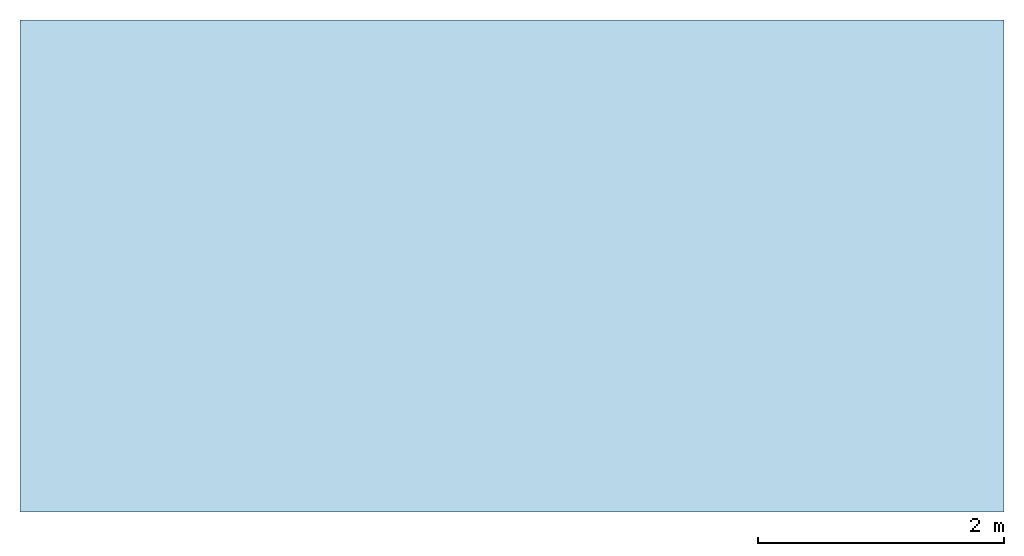
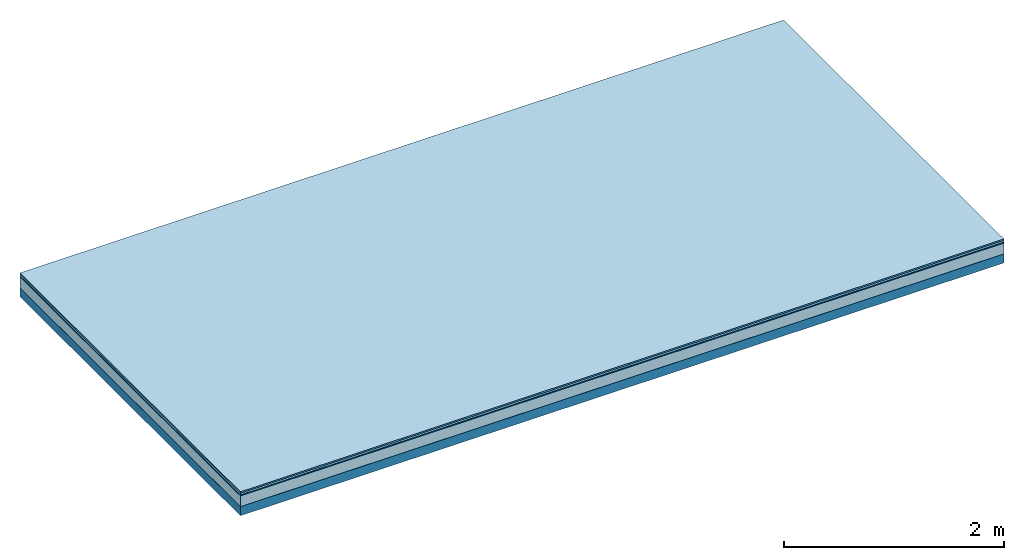
# One storey: 5 plates, 1 member, 1 element without a shape of its own.
"""IFC4 building model written with IfcOpenShell, lengths in metres."""

from ifc_helpers import new_model, si_unit, derived_unit, direction, frame, frame_2d, origin, origin_with_axes, place, context, project, spatial, rectangle, extrude, material, layer, layer_set, type_object, element, aggregate, save


model = new_model("IFC4")

# Units and contexts
plan_context = context("Plan", 3, precision=1e-05, world=origin(), true_north=direction((0.0, 1.0)))
model_context = context("Model", 3, precision=1e-05, world=origin(), true_north=direction((0.0, 1.0)))
ifc_project = project(units=[si_unit("LENGTHUNIT", "METRE"), derived_unit("SOUNDPRESSUREUNIT", [(si_unit("PRESSUREUNIT", "PASCAL", prefix="MICRO"), 0)]), si_unit("ENERGYUNIT", "JOULE", prefix="MEGA"), si_unit("MASSUNIT", "GRAM", prefix="KILO"), derived_unit("THERMALTRANSMITTANCEUNIT", [(si_unit("POWERUNIT", "WATT"), 1), (si_unit("AREAUNIT", "SQUARE_METRE"), -1), (si_unit("THERMODYNAMICTEMPERATUREUNIT", "KELVIN"), -1)]), derived_unit("AREADENSITYUNIT", [(si_unit("MASSUNIT", "GRAM", prefix="KILO"), 1), (si_unit("AREAUNIT", "SQUARE_METRE"), -1)]), derived_unit("USERDEFINED", [(si_unit("ENERGYUNIT", "JOULE", prefix="MEGA"), 1), (si_unit("AREAUNIT", "SQUARE_METRE"), -1)])], contexts=[plan_context, model_context])

# Site, building, storey
site = spatial("IfcSite", under=ifc_project)
building_placement = place(None, origin())
building = spatial("IfcBuilding", under=site, at=building_placement)
storey_placement = place(building_placement, origin())
storey = spatial("IfcBuildingStorey", under=building, at=storey_placement)

# Slab, member, plates
ifc_material_1 = material(Category="11.013")
ifc_layer_1 = layer(ifc_material_1, 0.015, Name="Flooring")
ifc_material_2 = material(Category="03.007")
ifc_layer_2 = layer(ifc_material_2, 0.02, Name="On-material")
ifc_material_3 = material(Name="Wood fiber generic product", Category="10.009")
ifc_layer_3 = layer(ifc_material_3, 0.01, Name="Impact sound insulation")
ifc_material_4 = material(Category="03.011")
ifc_layer_4 = layer(ifc_material_4, 0.12, Name="on Supporting structure")
ifc_material_5 = material(Name="protection", Category="09.007")
ifc_layer_5 = layer(ifc_material_5, 0.0005, Name="Sub-floor")
ifc_material_6 = material(Name="no composite action")
ifc_layer_6 = layer(ifc_material_6, 0.0, Name="Bond")
ifc_layer_7 = layer(None, 0.1, Name="Supporting structure")
ifc_layer_set = layer_set([ifc_layer_1, ifc_layer_2, ifc_layer_3, ifc_layer_4, ifc_layer_5, ifc_layer_6, ifc_layer_7])
slab_type = type_object("IfcSlabType", Name="A2050", PredefinedType="NOTDEFINED", material=ifc_layer_set)
slab_placement = place(None, frame((0.0, 0.0, 0.0), z_axis=(0.0, 0.0, -1.0), x_axis=(1.0, 0.0, 0.0)))
slab = element("IfcSlab", 1, at=slab_placement, inside=storey, type_object=slab_type, material=ifc_layer_set, Name="Slab #1")
ifc_material_7 = material(Name="Solid timber panel")
member_placement = place(slab_placement, origin())
member = element("IfcMember", 2, at=member_placement, material=ifc_material_7, Name="Supporting structure", context=plan_context, shape_type="SweptSolid", body=[
    extrude(rectangle(XDim=1.0, YDim=0.1, at=frame_2d((0.5, 0.05), x_axis=(1.0, 0.0))), frame((0.0, 4.0, 0.1655), z_axis=(0.0, -1.0, 0.0), x_axis=(1.0, 0.0, 0.0)), (0.0, 0.0, 1.0), 4.0),
    extrude(rectangle(XDim=1.0, YDim=0.1, at=frame_2d((0.5, 0.05), x_axis=(1.0, 0.0))), frame((1.0, 4.0, 0.1655), z_axis=(0.0, -1.0, 0.0), x_axis=(1.0, 0.0, 0.0)), (0.0, 0.0, 1.0), 4.0),
    extrude(rectangle(XDim=1.0, YDim=0.1, at=frame_2d((0.5, 0.05), x_axis=(1.0, 0.0))), frame((2.0, 4.0, 0.1655), z_axis=(0.0, -1.0, 0.0), x_axis=(1.0, 0.0, 0.0)), (0.0, 0.0, 1.0), 4.0),
    extrude(rectangle(XDim=1.0, YDim=0.1, at=frame_2d((0.5, 0.05), x_axis=(1.0, 0.0))), frame((3.0, 4.0, 0.1655), z_axis=(0.0, -1.0, 0.0), x_axis=(1.0, 0.0, 0.0)), (0.0, 0.0, 1.0), 4.0),
    extrude(rectangle(XDim=1.0, YDim=0.1, at=frame_2d((0.5, 0.05), x_axis=(1.0, 0.0))), frame((4.0, 4.0, 0.1655), z_axis=(0.0, -1.0, 0.0), x_axis=(1.0, 0.0, 0.0)), (0.0, 0.0, 1.0), 4.0),
    extrude(rectangle(XDim=1.0, YDim=0.1, at=frame_2d((0.5, 0.05), x_axis=(1.0, 0.0))), frame((5.0, 4.0, 0.1655), z_axis=(0.0, -1.0, 0.0), x_axis=(1.0, 0.0, 0.0)), (0.0, 0.0, 1.0), 4.0),
    extrude(rectangle(XDim=1.0, YDim=0.1, at=frame_2d((0.5, 0.05), x_axis=(1.0, 0.0))), frame((6.0, 4.0, 0.1655), z_axis=(0.0, -1.0, 0.0), x_axis=(1.0, 0.0, 0.0)), (0.0, 0.0, 1.0), 4.0),
    extrude(rectangle(XDim=1.0, YDim=0.1, at=frame_2d((0.5, 0.05), x_axis=(1.0, 0.0))), frame((7.0, 4.0, 0.1655), z_axis=(0.0, -1.0, 0.0), x_axis=(1.0, 0.0, 0.0)), (0.0, 0.0, 1.0), 4.0),
])
plate_1_placement = place(slab_placement, origin())
plate_1 = element("IfcPlate", 3, at=plate_1_placement, material=ifc_material_1, Name="Flooring", context=plan_context, shape_type="SweptSolid", body=[
    extrude(rectangle(XDim=8.0, YDim=4.0, at=frame_2d((4.0, 2.0), x_axis=(1.0, 0.0))), origin_with_axes(), (0.0, 0.0, 1.0), 0.015),
])
plate_2_placement = place(slab_placement, origin())
plate_2 = element("IfcPlate", 4, at=plate_2_placement, material=ifc_material_2, Name="On-material", context=plan_context, shape_type="SweptSolid", body=[
    extrude(rectangle(XDim=8.0, YDim=4.0, at=frame_2d((4.0, 2.0), x_axis=(1.0, 0.0))), frame((0.0, 0.0, 0.015), z_axis=(0.0, 0.0, 1.0), x_axis=(1.0, 0.0, 0.0)), (0.0, 0.0, 1.0), 0.02),
])
plate_3_placement = place(slab_placement, origin())
plate_3 = element("IfcPlate", 5, at=plate_3_placement, material=ifc_material_3, Name="Impact sound insulation", context=plan_context, shape_type="SweptSolid", body=[
    extrude(rectangle(XDim=8.0, YDim=4.0, at=frame_2d((4.0, 2.0), x_axis=(1.0, 0.0))), frame((0.0, 0.0, 0.035), z_axis=(0.0, 0.0, 1.0), x_axis=(1.0, 0.0, 0.0)), (0.0, 0.0, 1.0), 0.01),
])
plate_4_placement = place(slab_placement, origin())
plate_4 = element("IfcPlate", 6, at=plate_4_placement, material=ifc_material_4, Name="on Supporting structure", context=plan_context, shape_type="SweptSolid", body=[
    extrude(rectangle(XDim=8.0, YDim=4.0, at=frame_2d((4.0, 2.0), x_axis=(1.0, 0.0))), frame((0.0, 0.0, 0.045), z_axis=(0.0, 0.0, 1.0), x_axis=(1.0, 0.0, 0.0)), (0.0, 0.0, 1.0), 0.12),
])
plate_5_placement = place(slab_placement, origin())
plate_5 = element("IfcPlate", 7, at=plate_5_placement, material=ifc_material_5, Name="Sub-floor", context=plan_context, shape_type="SweptSolid", body=[
    extrude(rectangle(XDim=8.0, YDim=4.0, at=frame_2d((4.0, 2.0), x_axis=(1.0, 0.0))), frame((0.0, 0.0, 0.165), z_axis=(0.0, 0.0, 1.0), x_axis=(1.0, 0.0, 0.0)), (0.0, 0.0, 1.0), 0.0005),
])
aggregate(slab, [plate_1, plate_2, plate_3, plate_4, plate_5, member])

save(model, "model.ifc")
